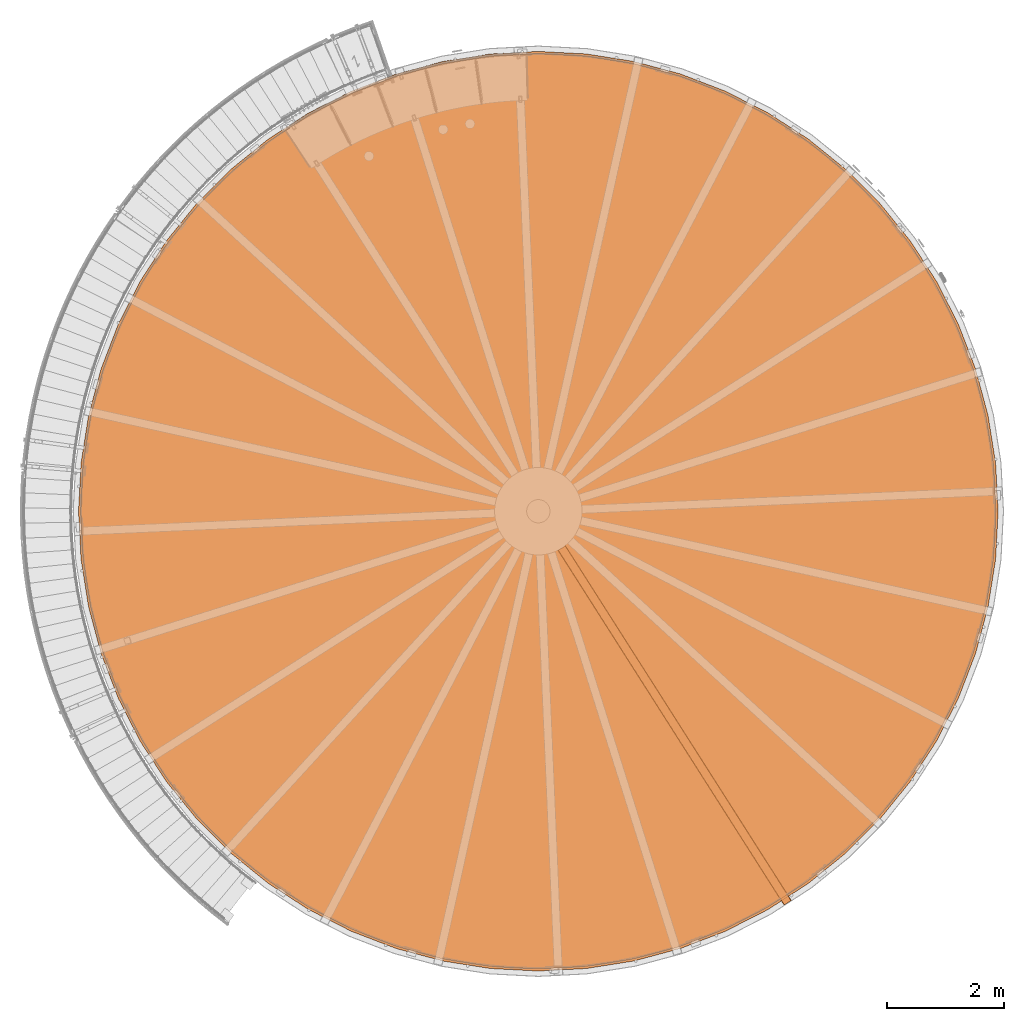
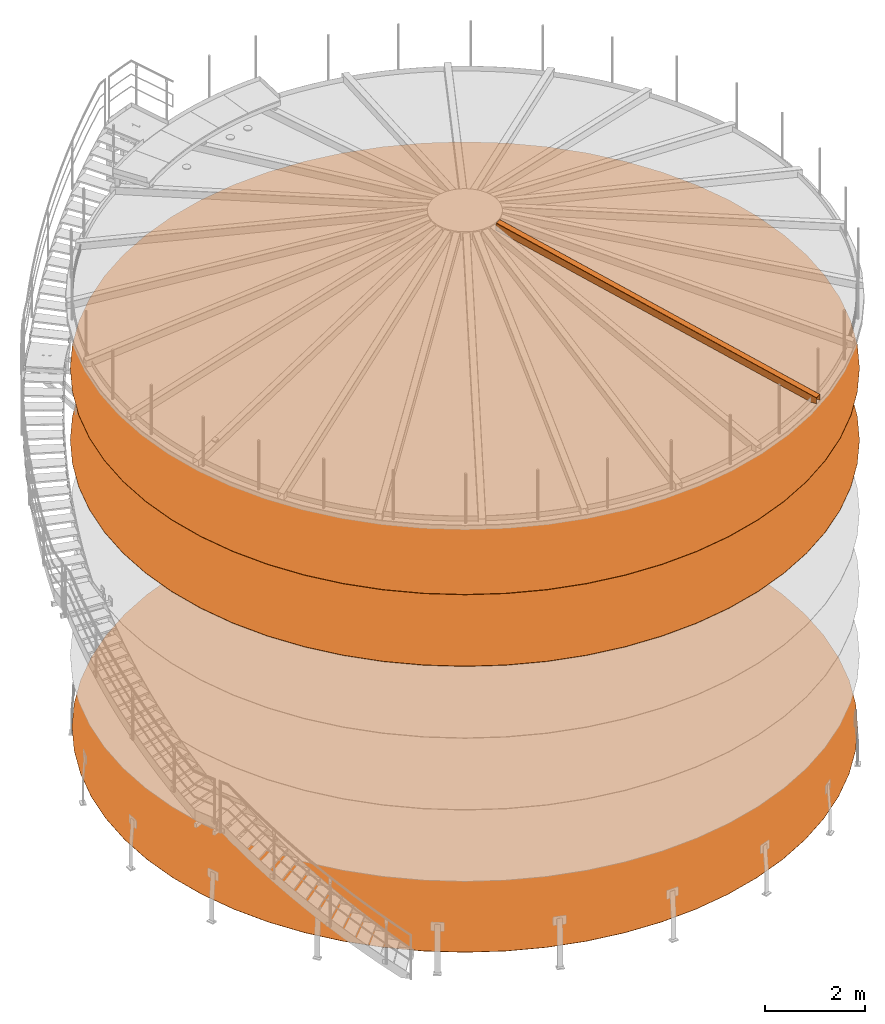
# One storey, part 19 of 126: 4 proxies.
"""IFC2X3 building model written with IfcOpenShell, lengths in millimetres."""

import ifcopenshell
import ifcopenshell.guid

model = None  # the IFC model being written
_history = None  # IfcOwnerHistory: only IFC2X3 demands one
_inside = {}  # id of a spatial element -> (the spatial element, [elements in it])
_under = {}  # id of a project, library or spatial element -> (it, [spatial elements below it])
_declared = {}  # id of a project -> (the project, [libraries it declares])
_typed = {}  # id of a type object -> (the type object, [elements of that type])
_made_of = {}  # id of a material, layer set ... -> (it, [elements and type objects made of it])


def new_model(schema):
    """Start an empty IFC model of exactly this schema.

    Asked for "IFC4X3", IfcOpenShell would pick the latest addendum, in which some entities
    have other attributes; the version numbers below select the first issue.
    IFC2X3 requires an IfcOwnerHistory on every rooted entity: one is made here for all.
    """
    global model, _history
    if schema == "IFC4X3":
        model = ifcopenshell.file(schema_version=(4, 3, 0, 0))
    else:
        model = ifcopenshell.file(schema=schema)
    _inside.clear()
    _under.clear()
    _declared.clear()
    _typed.clear()
    _made_of.clear()
    _history = None
    if model.schema == "IFC2X3":
        org = make("IfcOrganization", Name="unknown")
        user = make(
            "IfcPersonAndOrganization",
            ThePerson=make("IfcPerson", FamilyName="unknown"),
            TheOrganization=org,
        )
        app = make(
            "IfcApplication",
            ApplicationDeveloper=org,
            Version="unknown",
            ApplicationFullName="unknown",
            ApplicationIdentifier="unknown",
        )
        _history = make(
            "IfcOwnerHistory",
            OwningUser=user,
            OwningApplication=app,
            ChangeAction="ADDED",
            CreationDate=0,
        )
    return model


def make(cls, **values):
    """One entity of the class cls with the attributes given. An attribute that is None is left unset."""
    return model.create_entity(
        cls, **{name: value for name, value in values.items() if value is not None}
    )


def rooted(cls, **values):
    """An entity with a GlobalId (a new one), such as an element, a storey or a relation."""
    return make(cls, GlobalId=ifcopenshell.guid.new(), OwnerHistory=_history, **values)


def si_unit(unit_type, name, prefix=None):
    """IfcSIUnit, for example si_unit("LENGTHUNIT", "METRE", prefix="MILLI")."""
    return make("IfcSIUnit", UnitType=unit_type, Prefix=prefix, Name=name)


def assignment(units):
    """IfcUnitAssignment: the units of a project."""
    return None if units is None else make("IfcUnitAssignment", Units=units)


def point(xyz):
    """IfcCartesianPoint."""
    return None if xyz is None else make("IfcCartesianPoint", Coordinates=xyz)


def direction(xyz):
    """IfcDirection."""
    return None if xyz is None else make("IfcDirection", DirectionRatios=xyz)


def frame(location, z_axis=None, x_axis=None):
    """IfcAxis2Placement3D, a coordinate frame: its origin and axes. An axis left out is left unset."""
    return make(
        "IfcAxis2Placement3D",
        Location=point(location),
        Axis=direction(z_axis),
        RefDirection=direction(x_axis),
    )


def origin():
    """The frame at (0, 0, 0) with its axes left unset."""
    return frame((0.0, 0.0, 0.0))


def origin_with_axes():
    """The frame at (0, 0, 0) with the z axis (0, 0, 1) and the x axis (1, 0, 0) written out."""
    return frame((0.0, 0.0, 0.0), z_axis=(0.0, 0.0, 1.0), x_axis=(1.0, 0.0, 0.0))


def place(relative_to, where):
    """IfcLocalPlacement: puts the frame where relative to a parent placement (None: the world)."""
    return make(
        "IfcLocalPlacement", PlacementRelTo=relative_to, RelativePlacement=where
    )


def context(
    kind, dimensions, precision=None, world=None, true_north=None, identifier=None
):
    """IfcGeometricRepresentationContext, for example the 3D "Model" context."""
    return make(
        "IfcGeometricRepresentationContext",
        ContextIdentifier=identifier,
        ContextType=kind,
        CoordinateSpaceDimension=dimensions,
        Precision=precision,
        WorldCoordinateSystem=world,
        TrueNorth=true_north,
    )


def project(units=None, contexts=None):
    """IfcProject with its units and contexts."""
    return rooted(
        "IfcProject",
        Name="project",
        RepresentationContexts=contexts,
        UnitsInContext=assignment(units),
    )


def spatial(cls, under=None, at=None, **own):
    """A site, building, storey or space (cls), placed at a placement, below another one or the project."""
    s = rooted(cls, ObjectPlacement=at, **own)
    if under is not None:
        _under.setdefault(under.id(), (under, []))[1].append(s)
    return s


def faces_of(points, faces, orient=None, outer=None):
    """IfcFace entities. A face is a list of loops; a loop is a list of indices into points, from 0.

    orient and outer hold one flag for each loop. By default every Orientation is true, the
    first loop of a face is its IfcFaceOuterBound and the others are IfcFaceBound.
    """
    made = []
    for i, loops in enumerate(faces):
        bounds = []
        for j, loop in enumerate(loops):
            is_outer = j == 0 if outer is None else outer[i][j]
            bounds.append(
                make(
                    "IfcFaceOuterBound" if is_outer else "IfcFaceBound",
                    Bound=make("IfcPolyLoop", Polygon=[points[k] for k in loop]),
                    Orientation=True if orient is None else orient[i][j],
                )
            )
        made.append(make("IfcFace", Bounds=bounds))
    return made


def faceted_brep(points, faces, orient=None, outer=None, voids=None):
    """IfcFacetedBrep: a solid bounded by flat faces; with voids (closed shells), ...WithVoids."""
    shared = [point(p) for p in points]
    hull = make("IfcClosedShell", CfsFaces=faces_of(shared, faces, orient, outer))
    if voids is None:
        return make("IfcFacetedBrep", Outer=hull)
    return make(
        "IfcFacetedBrepWithVoids",
        Outer=hull,
        Voids=[
            make(cls, CfsFaces=faces_of(shared, fs, o, b)) for cls, fs, o, b in voids
        ],
    )


def shape(context_of_items, identifier, shape_type, items):
    """IfcShapeRepresentation: the items that make up one representation, for example the "Body"."""
    return make(
        "IfcShapeRepresentation",
        ContextOfItems=context_of_items,
        RepresentationIdentifier=identifier,
        RepresentationType=shape_type,
        Items=items,
    )


def material(Name=None, Category=None):
    """IfcMaterial."""
    return make("IfcMaterial", Name=Name, Category=Category)


def made_of(thing, what):
    """Note that an element or type object is made of a material, layer set ...; save() writes the relation."""
    if what is not None:
        _made_of.setdefault(what.id(), (what, []))[1].append(thing)
    return thing


def element(
    cls,
    number,
    at=None,
    inside=None,
    cuts=None,
    type_object=None,
    material=None,
    context=None,
    identifier="Body",
    shape_type=None,
    held_by="IfcProductDefinitionShape",
    body=None,
    shapes=None,
    **own,
):
    """One element of the class cls, such as IfcWall. Its Tag is "e" and its number.

    at: its placement. inside: the storey or other place that contains it. cuts: it is an
    opening in that element (IfcRelVoidsElement). A single representation is given by context,
    identifier, shape_type and body (its items); several are given by shapes. held_by: the class
    of the entity that holds the representations. save() writes the other relations.
    """
    e = rooted(cls, Tag="e%d" % number, ObjectPlacement=at, **own)
    if body is not None:
        shapes = [shape(context, identifier, shape_type, body)]
    if shapes is not None:
        e.Representation = make(held_by, Representations=shapes)
    if inside is not None:
        _inside.setdefault(inside.id(), (inside, []))[1].append(e)
    if cuts is not None:
        rooted(
            "IfcRelVoidsElement", RelatingBuildingElement=cuts, RelatedOpeningElement=e
        )
    if type_object is not None:
        _typed.setdefault(type_object.id(), (type_object, []))[1].append(e)
    return made_of(e, material)


def aggregate(whole, parts):
    """IfcRelAggregates: a whole, such as a stair, and the parts it consists of."""
    return rooted("IfcRelAggregates", RelatingObject=whole, RelatedObjects=parts)


def save(model, path):
    """Write the relations noted so far, then the file.

    IfcRelAggregates (storeys below a building ...), IfcRelContainedInSpatialStructure (elements
    in a storey), IfcRelDefinesByType, IfcRelAssociatesMaterial and IfcRelDeclares: one each for
    every whole, place, type object, material and project.
    """
    for whole, parts in _under.values():
        aggregate(whole, parts)
    for where, things in _inside.values():
        rooted(
            "IfcRelContainedInSpatialStructure",
            RelatedElements=things,
            RelatingStructure=where,
        )
    for kind, things in _typed.values():
        rooted("IfcRelDefinesByType", RelatedObjects=things, RelatingType=kind)
    for what, things in _made_of.values():
        rooted("IfcRelAssociatesMaterial", RelatedObjects=things, RelatingMaterial=what)
    for by, libraries in _declared.values():
        rooted("IfcRelDeclares", RelatingContext=by, RelatedDefinitions=libraries)
    model.write(path)


model = new_model("IFC2X3")

# Units and contexts
context_of_model_1 = context(None, 3, precision=0.1, world=origin())
context_of_model_2 = context(None, 3, precision=0.1, world=origin())
ifc_project = project(units=[si_unit("LENGTHUNIT", "METRE", prefix="MILLI"), si_unit("AREAUNIT", "SQUARE_METRE", prefix="CENTI"), si_unit("VOLUMEUNIT", "CUBIC_METRE", prefix="CENTI"), si_unit("MASSUNIT", "GRAM", prefix="KILO")], contexts=[context_of_model_1, context_of_model_2])

# Site, building, storey
site_placement = place(None, origin_with_axes())
site = spatial("IfcSite", under=ifc_project, at=site_placement, CompositionType="ELEMENT")
building_placement = place(site_placement, origin_with_axes())
building = spatial("IfcBuilding", under=site, at=building_placement, CompositionType="ELEMENT")
storey_placement = place(building_placement, origin_with_axes())
storey = spatial("IfcBuildingStorey", under=building, at=storey_placement, CompositionType="ELEMENT")

# Proxies
ifc_material = material(Name="STAHL")
proxy_1_placement = place(storey_placement, origin_with_axes())
element("IfcBuildingElementProxy", 1, at=proxy_1_placement, inside=storey, material=ifc_material, Name="profile", context=context_of_model_2, shape_type="Brep", body=[
    faceted_brep([(4812.1, 833.7, 0.0), (5579.2, 539.2, 0.0), (5579.2, 539.2, 6.0), (4812.1, 833.7, 6.0), (4080.0, 1206.7, 0.0), (4080.0, 1206.7, 6.0), (3390.9, 1654.2, 0.0), (3390.9, 1654.2, 6.0), (15812.0, 7184.5, 0.0), (15855.0, 8005.0, 0.0), (15855.0, 8005.0, 6.0), (15812.0, 7184.5, 6.0), (2752.3, 2171.3, 0.0), (2752.3, 2171.3, 6.0), (15683.5, 6372.9, 0.0), (15683.5, 6372.9, 6.0), (2171.3, 2752.3, 0.0), (2171.3, 2752.3, 6.0), (15470.8, 5579.2, 0.0), (15470.8, 5579.2, 6.0), (1654.2, 3390.9, 0.0), (1654.2, 3390.9, 6.0), (15176.3, 4812.1, 0.0), (15176.3, 4812.1, 6.0), (1206.7, 4080.0, 0.0), (1206.7, 4080.0, 6.0), (14803.3, 4080.0, 0.0), (14803.3, 4080.0, 6.0), (833.7, 4812.1, 0.0), (833.7, 4812.1, 6.0), (14355.8, 3390.9, 0.0), (14355.8, 3390.9, 6.0), (539.2, 5579.2, 0.0), (539.2, 5579.2, 6.0), (13838.7, 2752.3, 0.0), (13838.7, 2752.3, 6.0), (326.5, 6372.9, 0.0), (326.5, 6372.9, 6.0), (13257.7, 2171.3, 0.0), (13257.7, 2171.3, 6.0), (198.0, 7184.5, 0.0), (198.0, 7184.5, 6.0), (12619.1, 1654.2, 0.0), (12619.1, 1654.2, 6.0), (155.0, 8005.0, 0.0), (155.0, 8005.0, 6.0), (11930.0, 1206.7, 0.0), (11930.0, 1206.7, 6.0), (11197.9, 833.7, 0.0), (11197.9, 833.7, 6.0), (10430.8, 539.2, 0.0), (10430.8, 539.2, 6.0), (9637.1, 326.5, 0.0), (9637.1, 326.5, 6.0), (8825.5, 198.0, 0.0), (8825.5, 198.0, 6.0), (8005.0, 155.0, 0.0), (8005.0, 155.0, 6.0), (7184.5, 198.0, 0.0), (7184.5, 198.0, 6.0), (6372.9, 326.5, 0.0), (6372.9, 326.5, 6.0), (11197.9, 15176.3, 0.0), (10430.8, 15470.8, 0.0), (10430.8, 15470.8, 6.0), (11197.9, 15176.3, 6.0), (11930.0, 14803.3, 0.0), (11930.0, 14803.3, 6.0), (12619.1, 14355.8, 0.0), (12619.1, 14355.8, 6.0), (198.0, 8825.5, 0.0), (198.0, 8825.5, 6.0), (13257.7, 13838.7, 0.0), (13257.7, 13838.7, 6.0), (326.5, 9637.1, 0.0), (326.5, 9637.1, 6.0), (13838.7, 13257.7, 0.0), (13838.7, 13257.7, 6.0), (539.2, 10430.8, 0.0), (539.2, 10430.8, 6.0), (14355.8, 12619.1, 0.0), (14355.8, 12619.1, 6.0), (833.7, 11197.9, 0.0), (833.7, 11197.9, 6.0), (14803.3, 11930.0, 0.0), (14803.3, 11930.0, 6.0), (1206.7, 11930.0, 0.0), (1206.7, 11930.0, 6.0), (15176.3, 11197.9, 0.0), (15176.3, 11197.9, 6.0), (1654.2, 12619.1, 0.0), (1654.2, 12619.1, 6.0), (15470.8, 10430.8, 0.0), (15470.8, 10430.8, 6.0), (2171.3, 13257.7, 0.0), (2171.3, 13257.7, 6.0), (15683.5, 9637.1, 0.0), (15683.5, 9637.1, 6.0), (2752.3, 13838.7, 0.0), (2752.3, 13838.7, 6.0), (15812.0, 8825.5, 0.0), (15812.0, 8825.5, 6.0), (3390.9, 14355.8, 0.0), (3390.9, 14355.8, 6.0), (4080.0, 14803.3, 0.0), (4080.0, 14803.3, 6.0), (4812.1, 15176.3, 0.0), (4812.1, 15176.3, 6.0), (5579.2, 15470.8, 0.0), (5579.2, 15470.8, 6.0), (6372.9, 15683.5, 0.0), (6372.9, 15683.5, 6.0), (7184.5, 15812.0, 0.0), (7184.5, 15812.0, 6.0), (8005.0, 15855.0, 0.0), (8005.0, 15855.0, 6.0), (8825.5, 15812.0, 0.0), (8825.5, 15812.0, 6.0), (9637.1, 15683.5, 0.0), (9637.1, 15683.5, 6.0)], [[[0, 1, 2, 3]], [[4, 0, 3, 5]], [[6, 4, 5, 7]], [[8, 9, 10, 11]], [[12, 6, 7, 13]], [[14, 8, 11, 15]], [[16, 12, 13, 17]], [[18, 14, 15, 19]], [[20, 16, 17, 21]], [[22, 18, 19, 23]], [[24, 20, 21, 25]], [[26, 22, 23, 27]], [[28, 24, 25, 29]], [[30, 26, 27, 31]], [[32, 28, 29, 33]], [[34, 30, 31, 35]], [[36, 32, 33, 37]], [[38, 34, 35, 39]], [[40, 36, 37, 41]], [[42, 38, 39, 43]], [[44, 40, 41, 45]], [[46, 42, 43, 47]], [[48, 46, 47, 49]], [[50, 48, 49, 51]], [[52, 50, 51, 53]], [[54, 52, 53, 55]], [[56, 54, 55, 57]], [[58, 56, 57, 59]], [[60, 58, 59, 61]], [[1, 60, 61, 2]], [[62, 63, 64, 65]], [[66, 62, 65, 67]], [[68, 66, 67, 69]], [[70, 44, 45, 71]], [[72, 68, 69, 73]], [[74, 70, 71, 75]], [[76, 72, 73, 77]], [[78, 74, 75, 79]], [[80, 76, 77, 81]], [[82, 78, 79, 83]], [[84, 80, 81, 85]], [[86, 82, 83, 87]], [[88, 84, 85, 89]], [[90, 86, 87, 91]], [[92, 88, 89, 93]], [[94, 90, 91, 95]], [[96, 92, 93, 97]], [[98, 94, 95, 99]], [[100, 96, 97, 101]], [[102, 98, 99, 103]], [[9, 100, 101, 10]], [[104, 102, 103, 105]], [[106, 104, 105, 107]], [[108, 106, 107, 109]], [[110, 108, 109, 111]], [[112, 110, 111, 113]], [[114, 112, 113, 115]], [[116, 114, 115, 117]], [[118, 116, 117, 119]], [[63, 118, 119, 64]], [[56, 58, 60, 1, 0, 4, 6, 12, 16, 20, 24, 28, 32, 36, 40, 44, 70, 74, 78, 82, 86, 90, 94, 98, 102, 104, 106, 108, 110, 112, 114, 116, 118, 63, 62, 66, 68, 72, 76, 80, 84, 88, 92, 96, 100, 9, 8, 14, 18, 22, 26, 30, 34, 38, 42, 46, 48, 50, 52, 54]], [[57, 55, 53, 51, 49, 47, 43, 39, 35, 31, 27, 23, 19, 15, 11, 10, 101, 97, 93, 89, 85, 81, 77, 73, 69, 67, 65, 64, 119, 117, 115, 113, 111, 109, 107, 105, 103, 99, 95, 91, 87, 83, 79, 75, 71, 45, 41, 37, 33, 29, 25, 21, 17, 13, 7, 5, 3, 2, 61, 59]]]),
])
proxy_2_placement = place(storey_placement, origin_with_axes())
element("IfcBuildingElementProxy", 2, at=proxy_2_placement, inside=storey, material=ifc_material, Name="profile", context=context_of_model_2, shape_type="Brep", body=[
    faceted_brep([(4062.5, 14833.6, 8756.0), (4797.9, 15208.3, 8756.0), (4797.9, 15208.3, 8748.0), (4062.5, 14833.6, 8748.0), (15890.0, 8005.0, 8756.0), (15890.0, 8005.0, 8748.0), (15846.8, 8829.2, 8748.0), (15846.8, 8829.2, 8756.0), (3370.3, 14384.1, 8756.0), (3370.3, 14384.1, 8748.0), (15717.7, 9644.4, 8748.0), (15717.7, 9644.4, 8756.0), (2728.9, 13864.7, 8756.0), (2728.9, 13864.7, 8748.0), (2145.3, 13281.1, 8756.0), (2145.3, 13281.1, 8748.0), (15504.1, 10441.6, 8756.0), (15504.1, 10441.6, 8748.0), (1625.9, 12639.7, 8756.0), (1625.9, 12639.7, 8748.0), (15208.3, 11212.1, 8756.0), (15208.3, 11212.1, 8748.0), (1176.4, 11947.5, 8756.0), (1176.4, 11947.5, 8748.0), (14833.6, 11947.5, 8756.0), (14833.6, 11947.5, 8748.0), (801.7, 11212.1, 8756.0), (801.7, 11212.1, 8748.0), (14384.1, 12639.7, 8756.0), (14384.1, 12639.7, 8748.0), (505.9, 10441.6, 8756.0), (505.9, 10441.6, 8748.0), (13864.7, 13281.1, 8756.0), (13864.7, 13281.1, 8748.0), (292.3, 9644.4, 8756.0), (292.3, 9644.4, 8748.0), (13281.1, 13864.7, 8756.0), (13281.1, 13864.7, 8748.0), (163.2, 8829.2, 8756.0), (163.2, 8829.2, 8748.0), (12639.7, 14384.1, 8756.0), (12639.7, 14384.1, 8748.0), (120.0, 8005.0, 8756.0), (120.0, 8005.0, 8748.0), (11947.5, 14833.6, 8756.0), (11947.5, 14833.6, 8748.0), (11212.1, 15208.3, 8756.0), (11212.1, 15208.3, 8748.0), (10441.6, 15504.1, 8756.0), (10441.6, 15504.1, 8748.0), (9644.4, 15717.7, 8756.0), (9644.4, 15717.7, 8748.0), (8829.2, 15846.8, 8756.0), (8829.2, 15846.8, 8748.0), (8005.0, 15890.0, 8756.0), (8005.0, 15890.0, 8748.0), (7180.8, 15846.8, 8756.0), (7180.8, 15846.8, 8748.0), (6365.6, 15717.7, 8756.0), (6365.6, 15717.7, 8748.0), (5568.4, 15504.1, 8756.0), (5568.4, 15504.1, 8748.0), (11179.6, 874.8, 8756.0), (11179.6, 874.8, 8748.0), (10416.9, 582.0, 8748.0), (10416.9, 582.0, 8756.0), (11907.5, 1245.7, 8756.0), (11907.5, 1245.7, 8748.0), (200.0, 8005.0, 8756.0), (242.8, 7189.2, 8756.0), (242.8, 7189.2, 8748.0), (200.0, 8005.0, 8748.0), (12592.7, 1690.6, 8756.0), (12592.7, 1690.6, 8748.0), (13227.6, 2204.8, 8756.0), (13227.6, 2204.8, 8748.0), (370.6, 6382.2, 8756.0), (370.6, 6382.2, 8748.0), (13805.2, 2782.4, 8756.0), (13805.2, 2782.4, 8748.0), (582.0, 5593.1, 8756.0), (582.0, 5593.1, 8748.0), (14319.4, 3417.3, 8756.0), (14319.4, 3417.3, 8748.0), (874.8, 4830.4, 8756.0), (874.8, 4830.4, 8748.0), (14764.3, 4102.5, 8756.0), (14764.3, 4102.5, 8748.0), (1245.7, 4102.5, 8756.0), (1245.7, 4102.5, 8748.0), (15135.2, 4830.4, 8756.0), (15135.2, 4830.4, 8748.0), (1690.6, 3417.3, 8756.0), (1690.6, 3417.3, 8748.0), (15428.0, 5593.1, 8756.0), (15428.0, 5593.1, 8748.0), (2204.8, 2782.4, 8756.0), (2204.8, 2782.4, 8748.0), (15639.4, 6382.2, 8756.0), (15639.4, 6382.2, 8748.0), (2782.4, 2204.8, 8756.0), (2782.4, 2204.8, 8748.0), (15767.2, 7189.2, 8756.0), (15767.2, 7189.2, 8748.0), (3417.3, 1690.6, 8756.0), (3417.3, 1690.6, 8748.0), (15810.0, 8005.0, 8756.0), (15810.0, 8005.0, 8748.0), (4102.5, 1245.7, 8756.0), (4102.5, 1245.7, 8748.0), (4830.4, 874.8, 8756.0), (4830.4, 874.8, 8748.0), (5593.1, 582.0, 8756.0), (5593.1, 582.0, 8748.0), (6382.2, 370.6, 8756.0), (6382.2, 370.6, 8748.0), (7189.2, 242.8, 8756.0), (7189.2, 242.8, 8748.0), (8005.0, 200.0, 8756.0), (8005.0, 200.0, 8748.0), (8820.8, 242.8, 8756.0), (8820.8, 242.8, 8748.0), (9627.8, 370.6, 8756.0), (9627.8, 370.6, 8748.0), (8005.0, 120.0, 8756.0), (8829.2, 163.2, 8756.0), (9644.4, 292.3, 8756.0), (10441.6, 505.9, 8756.0), (11212.1, 801.7, 8756.0), (11947.5, 1176.4, 8756.0), (12639.7, 1625.9, 8756.0), (13281.1, 2145.3, 8756.0), (13864.7, 2728.9, 8756.0), (14384.1, 3370.3, 8756.0), (14833.6, 4062.5, 8756.0), (15208.3, 4797.9, 8756.0), (15504.1, 5568.4, 8756.0), (15717.7, 6365.6, 8756.0), (15846.8, 7180.8, 8756.0), (163.2, 7180.8, 8756.0), (292.3, 6365.6, 8756.0), (505.9, 5568.4, 8756.0), (801.7, 4797.9, 8756.0), (1176.4, 4062.5, 8756.0), (1625.9, 3370.3, 8756.0), (2145.3, 2728.9, 8756.0), (2728.9, 2145.3, 8756.0), (242.8, 8820.8, 8756.0), (370.6, 9627.8, 8756.0), (582.0, 10416.9, 8756.0), (874.8, 11179.6, 8756.0), (1245.7, 11907.5, 8756.0), (1690.6, 12592.7, 8756.0), (2204.8, 13227.6, 8756.0), (2782.4, 13805.2, 8756.0), (3417.3, 14319.4, 8756.0), (4102.5, 14764.3, 8756.0), (4830.4, 15135.2, 8756.0), (5593.1, 15428.0, 8756.0), (6382.2, 15639.4, 8756.0), (7189.2, 15767.2, 8756.0), (8005.0, 15810.0, 8756.0), (8820.8, 15767.2, 8756.0), (9627.8, 15639.4, 8756.0), (10416.9, 15428.0, 8756.0), (11179.6, 15135.2, 8756.0), (11907.5, 14764.3, 8756.0), (12592.7, 14319.4, 8756.0), (13227.6, 13805.2, 8756.0), (13805.2, 13227.6, 8756.0), (14319.4, 12592.7, 8756.0), (14764.3, 11907.5, 8756.0), (15135.2, 11179.6, 8756.0), (15428.0, 10416.9, 8756.0), (15639.4, 9627.8, 8756.0), (15767.2, 8820.8, 8756.0), (3370.3, 1625.9, 8756.0), (4062.5, 1176.4, 8756.0), (4797.9, 801.7, 8756.0), (5568.4, 505.9, 8756.0), (6365.6, 292.3, 8756.0), (7180.8, 163.2, 8756.0), (4830.4, 15135.2, 8748.0), (5593.1, 15428.0, 8748.0), (4102.5, 14764.3, 8748.0), (3417.3, 14319.4, 8748.0), (15767.2, 8820.8, 8748.0), (2782.4, 13805.2, 8748.0), (15639.4, 9627.8, 8748.0), (2204.8, 13227.6, 8748.0), (15428.0, 10416.9, 8748.0), (1690.6, 12592.7, 8748.0), (15135.2, 11179.6, 8748.0), (1245.7, 11907.5, 8748.0), (14764.3, 11907.5, 8748.0), (874.8, 11179.6, 8748.0), (14319.4, 12592.7, 8748.0), (582.0, 10416.9, 8748.0), (13805.2, 13227.6, 8748.0), (370.6, 9627.8, 8748.0), (13227.6, 13805.2, 8748.0), (242.8, 8820.8, 8748.0), (12592.7, 14319.4, 8748.0), (11907.5, 14764.3, 8748.0), (11179.6, 15135.2, 8748.0), (10416.9, 15428.0, 8748.0), (9627.8, 15639.4, 8748.0), (8820.8, 15767.2, 8748.0), (8005.0, 15810.0, 8748.0), (7189.2, 15767.2, 8748.0), (6382.2, 15639.4, 8748.0), (8005.0, 120.0, 8748.0), (7180.8, 163.2, 8748.0), (6365.6, 292.3, 8748.0), (5568.4, 505.9, 8748.0), (4797.9, 801.7, 8748.0), (4062.5, 1176.4, 8748.0), (3370.3, 1625.9, 8748.0), (2728.9, 2145.3, 8748.0), (2145.3, 2728.9, 8748.0), (1625.9, 3370.3, 8748.0), (1176.4, 4062.5, 8748.0), (801.7, 4797.9, 8748.0), (505.9, 5568.4, 8748.0), (292.3, 6365.6, 8748.0), (163.2, 7180.8, 8748.0), (15846.8, 7180.8, 8748.0), (15717.7, 6365.6, 8748.0), (15504.1, 5568.4, 8748.0), (15208.3, 4797.9, 8748.0), (14833.6, 4062.5, 8748.0), (14384.1, 3370.3, 8748.0), (13864.7, 2728.9, 8748.0), (13281.1, 2145.3, 8748.0), (12639.7, 1625.9, 8748.0), (11947.5, 1176.4, 8748.0), (11212.1, 801.7, 8748.0), (10441.6, 505.9, 8748.0), (9644.4, 292.3, 8748.0), (8829.2, 163.2, 8748.0)], [[[0, 1, 2, 3]], [[4, 5, 6, 7]], [[8, 0, 3, 9]], [[7, 6, 10, 11]], [[12, 8, 9, 13]], [[14, 12, 13, 15]], [[16, 11, 10, 17]], [[18, 14, 15, 19]], [[20, 16, 17, 21]], [[22, 18, 19, 23]], [[24, 20, 21, 25]], [[26, 22, 23, 27]], [[28, 24, 25, 29]], [[30, 26, 27, 31]], [[32, 28, 29, 33]], [[34, 30, 31, 35]], [[36, 32, 33, 37]], [[38, 34, 35, 39]], [[40, 36, 37, 41]], [[42, 38, 39, 43]], [[44, 40, 41, 45]], [[46, 44, 45, 47]], [[48, 46, 47, 49]], [[50, 48, 49, 51]], [[52, 50, 51, 53]], [[54, 52, 53, 55]], [[56, 54, 55, 57]], [[58, 56, 57, 59]], [[60, 58, 59, 61]], [[1, 60, 61, 2]], [[62, 63, 64, 65]], [[66, 67, 63, 62]], [[68, 69, 70, 71]], [[72, 73, 67, 66]], [[74, 75, 73, 72]], [[76, 77, 70, 69]], [[78, 79, 75, 74]], [[80, 81, 77, 76]], [[82, 83, 79, 78]], [[84, 85, 81, 80]], [[86, 87, 83, 82]], [[88, 89, 85, 84]], [[90, 91, 87, 86]], [[92, 93, 89, 88]], [[94, 95, 91, 90]], [[96, 97, 93, 92]], [[98, 99, 95, 94]], [[100, 101, 97, 96]], [[102, 103, 99, 98]], [[104, 105, 101, 100]], [[106, 107, 103, 102]], [[108, 109, 105, 104]], [[110, 111, 109, 108]], [[112, 113, 111, 110]], [[114, 115, 113, 112]], [[116, 117, 115, 114]], [[118, 119, 117, 116]], [[120, 121, 119, 118]], [[122, 123, 121, 120]], [[65, 64, 123, 122]], [[124, 125, 126, 127, 128, 129, 130, 131, 132, 133, 134, 135, 136, 137, 138, 4, 7, 11, 16, 20, 24, 28, 32, 36, 40, 44, 46, 48, 50, 52, 54, 56, 58, 60, 1, 0, 8, 12, 14, 18, 22, 26, 30, 34, 38, 42, 139, 140, 141, 142, 143, 144, 145, 146, 96, 92, 88, 84, 80, 76, 69, 68, 147, 148, 149, 150, 151, 152, 153, 154, 155, 156, 157, 158, 159, 160, 161, 162, 163, 164, 165, 166, 167, 168, 169, 170, 171, 172, 173, 174, 175, 106, 102, 98, 94, 90, 86, 82, 78, 74, 72, 66, 62, 65, 122, 120, 118, 116, 114, 112, 110, 108, 104, 100, 96, 146, 176, 177, 178, 179, 180, 181]], [[157, 182, 183, 158]], [[156, 184, 182, 157]], [[155, 185, 184, 156]], [[175, 186, 107, 106]], [[154, 187, 185, 155]], [[174, 188, 186, 175]], [[153, 189, 187, 154]], [[173, 190, 188, 174]], [[152, 191, 189, 153]], [[172, 192, 190, 173]], [[151, 193, 191, 152]], [[171, 194, 192, 172]], [[150, 195, 193, 151]], [[170, 196, 194, 171]], [[149, 197, 195, 150]], [[169, 198, 196, 170]], [[148, 199, 197, 149]], [[168, 200, 198, 169]], [[147, 201, 199, 148]], [[167, 202, 200, 168]], [[68, 71, 201, 147]], [[166, 203, 202, 167]], [[165, 204, 203, 166]], [[164, 205, 204, 165]], [[163, 206, 205, 164]], [[162, 207, 206, 163]], [[161, 208, 207, 162]], [[160, 209, 208, 161]], [[159, 210, 209, 160]], [[158, 183, 210, 159]], [[211, 212, 213, 214, 215, 216, 217, 218, 219, 220, 221, 222, 223, 224, 225, 43, 39, 35, 31, 27, 23, 19, 15, 13, 9, 3, 2, 61, 59, 57, 55, 53, 51, 49, 47, 45, 41, 37, 33, 29, 25, 21, 17, 10, 6, 5, 226, 227, 228, 229, 230, 231, 232, 75, 79, 83, 87, 91, 95, 99, 103, 107, 186, 188, 190, 192, 194, 196, 198, 200, 202, 203, 204, 205, 206, 207, 208, 209, 210, 183, 182, 184, 185, 187, 189, 191, 193, 195, 197, 199, 201, 71, 70, 77, 81, 85, 89, 93, 97, 101, 105, 109, 111, 113, 115, 117, 119, 121, 123, 64, 63, 67, 73, 75, 232, 233, 234, 235, 236, 237, 238, 239]], [[128, 127, 237, 236]], [[129, 128, 236, 235]], [[130, 129, 235, 234]], [[139, 42, 43, 225]], [[131, 130, 234, 233]], [[140, 139, 225, 224]], [[140, 224, 223, 141]], [[132, 131, 233, 232]], [[133, 132, 232, 231]], [[142, 141, 223, 222]], [[134, 133, 231, 230]], [[143, 142, 222, 221]], [[135, 134, 230, 229]], [[144, 143, 221, 220]], [[136, 135, 229, 228]], [[145, 144, 220, 219]], [[137, 136, 228, 227]], [[146, 145, 219, 218]], [[138, 137, 227, 226]], [[176, 146, 218, 217]], [[4, 138, 226, 5]], [[177, 176, 217, 216]], [[178, 177, 216, 215]], [[179, 178, 215, 214]], [[180, 179, 214, 213]], [[181, 180, 213, 212]], [[124, 181, 212, 211]], [[125, 124, 211, 239]], [[126, 125, 239, 238]], [[127, 126, 238, 237]]]),
])
proxy_3_placement = place(storey_placement, origin_with_axes())
element("IfcBuildingElementProxy", 3, at=proxy_3_placement, inside=storey, material=ifc_material, Name="profile", context=context_of_model_2, shape_type="Brep", body=[
    faceted_brep([(4062.5, 14833.6, 7006.0), (4797.9, 15208.3, 7006.0), (4797.9, 15208.3, 6998.0), (4062.5, 14833.6, 6998.0), (15890.0, 8005.0, 7006.0), (15890.0, 8005.0, 6998.0), (15846.8, 8829.2, 6998.0), (15846.8, 8829.2, 7006.0), (3370.3, 14384.1, 7006.0), (3370.3, 14384.1, 6998.0), (15717.7, 9644.4, 6998.0), (15717.7, 9644.4, 7006.0), (2728.9, 13864.7, 7006.0), (2728.9, 13864.7, 6998.0), (2145.3, 13281.1, 7006.0), (2145.3, 13281.1, 6998.0), (15504.1, 10441.6, 7006.0), (15504.1, 10441.6, 6998.0), (1625.9, 12639.7, 7006.0), (1625.9, 12639.7, 6998.0), (15208.3, 11212.1, 7006.0), (15208.3, 11212.1, 6998.0), (1176.4, 11947.5, 7006.0), (1176.4, 11947.5, 6998.0), (14833.6, 11947.5, 7006.0), (14833.6, 11947.5, 6998.0), (801.7, 11212.1, 7006.0), (801.7, 11212.1, 6998.0), (14384.1, 12639.7, 7006.0), (14384.1, 12639.7, 6998.0), (505.9, 10441.6, 7006.0), (505.9, 10441.6, 6998.0), (13864.7, 13281.1, 7006.0), (13864.7, 13281.1, 6998.0), (292.3, 9644.4, 7006.0), (292.3, 9644.4, 6998.0), (13281.1, 13864.7, 7006.0), (13281.1, 13864.7, 6998.0), (163.2, 8829.2, 7006.0), (163.2, 8829.2, 6998.0), (12639.7, 14384.1, 7006.0), (12639.7, 14384.1, 6998.0), (120.0, 8005.0, 7006.0), (120.0, 8005.0, 6998.0), (11947.5, 14833.6, 7006.0), (11947.5, 14833.6, 6998.0), (11212.1, 15208.3, 7006.0), (11212.1, 15208.3, 6998.0), (10441.6, 15504.1, 7006.0), (10441.6, 15504.1, 6998.0), (9644.4, 15717.7, 7006.0), (9644.4, 15717.7, 6998.0), (8829.2, 15846.8, 7006.0), (8829.2, 15846.8, 6998.0), (8005.0, 15890.0, 7006.0), (8005.0, 15890.0, 6998.0), (7180.8, 15846.8, 7006.0), (7180.8, 15846.8, 6998.0), (6365.6, 15717.7, 7006.0), (6365.6, 15717.7, 6998.0), (5568.4, 15504.1, 7006.0), (5568.4, 15504.1, 6998.0), (11179.6, 874.8, 7006.0), (11179.6, 874.8, 6998.0), (10416.9, 582.0, 6998.0), (10416.9, 582.0, 7006.0), (11907.5, 1245.7, 7006.0), (11907.5, 1245.7, 6998.0), (200.0, 8005.0, 7006.0), (242.8, 7189.2, 7006.0), (242.8, 7189.2, 6998.0), (200.0, 8005.0, 6998.0), (12592.7, 1690.6, 7006.0), (12592.7, 1690.6, 6998.0), (13227.6, 2204.8, 7006.0), (13227.6, 2204.8, 6998.0), (370.6, 6382.2, 7006.0), (370.6, 6382.2, 6998.0), (13805.2, 2782.4, 7006.0), (13805.2, 2782.4, 6998.0), (582.0, 5593.1, 7006.0), (582.0, 5593.1, 6998.0), (14319.4, 3417.3, 7006.0), (14319.4, 3417.3, 6998.0), (874.8, 4830.4, 7006.0), (874.8, 4830.4, 6998.0), (14764.3, 4102.5, 7006.0), (14764.3, 4102.5, 6998.0), (1245.7, 4102.5, 7006.0), (1245.7, 4102.5, 6998.0), (15135.2, 4830.4, 7006.0), (15135.2, 4830.4, 6998.0), (1690.6, 3417.3, 7006.0), (1690.6, 3417.3, 6998.0), (15428.0, 5593.1, 7006.0), (15428.0, 5593.1, 6998.0), (2204.8, 2782.4, 7006.0), (2204.8, 2782.4, 6998.0), (15639.4, 6382.2, 7006.0), (15639.4, 6382.2, 6998.0), (2782.4, 2204.8, 7006.0), (2782.4, 2204.8, 6998.0), (15767.2, 7189.2, 7006.0), (15767.2, 7189.2, 6998.0), (3417.3, 1690.6, 7006.0), (3417.3, 1690.6, 6998.0), (15810.0, 8005.0, 7006.0), (15810.0, 8005.0, 6998.0), (4102.5, 1245.7, 7006.0), (4102.5, 1245.7, 6998.0), (4830.4, 874.8, 7006.0), (4830.4, 874.8, 6998.0), (5593.1, 582.0, 7006.0), (5593.1, 582.0, 6998.0), (6382.2, 370.6, 7006.0), (6382.2, 370.6, 6998.0), (7189.2, 242.8, 7006.0), (7189.2, 242.8, 6998.0), (8005.0, 200.0, 7006.0), (8005.0, 200.0, 6998.0), (8820.8, 242.8, 7006.0), (8820.8, 242.8, 6998.0), (9627.8, 370.6, 7006.0), (9627.8, 370.6, 6998.0), (8005.0, 120.0, 7006.0), (8829.2, 163.2, 7006.0), (9644.4, 292.3, 7006.0), (10441.6, 505.9, 7006.0), (11212.1, 801.7, 7006.0), (11947.5, 1176.4, 7006.0), (12639.7, 1625.9, 7006.0), (13281.1, 2145.3, 7006.0), (13864.7, 2728.9, 7006.0), (14384.1, 3370.3, 7006.0), (14833.6, 4062.5, 7006.0), (15208.3, 4797.9, 7006.0), (15504.1, 5568.4, 7006.0), (15717.7, 6365.6, 7006.0), (15846.8, 7180.8, 7006.0), (163.2, 7180.8, 7006.0), (292.3, 6365.6, 7006.0), (505.9, 5568.4, 7006.0), (801.7, 4797.9, 7006.0), (1176.4, 4062.5, 7006.0), (1625.9, 3370.3, 7006.0), (2145.3, 2728.9, 7006.0), (2728.9, 2145.3, 7006.0), (242.8, 8820.8, 7006.0), (370.6, 9627.8, 7006.0), (582.0, 10416.9, 7006.0), (874.8, 11179.6, 7006.0), (1245.7, 11907.5, 7006.0), (1690.6, 12592.7, 7006.0), (2204.8, 13227.6, 7006.0), (2782.4, 13805.2, 7006.0), (3417.3, 14319.4, 7006.0), (4102.5, 14764.3, 7006.0), (4830.4, 15135.2, 7006.0), (5593.1, 15428.0, 7006.0), (6382.2, 15639.4, 7006.0), (7189.2, 15767.2, 7006.0), (8005.0, 15810.0, 7006.0), (8820.8, 15767.2, 7006.0), (9627.8, 15639.4, 7006.0), (10416.9, 15428.0, 7006.0), (11179.6, 15135.2, 7006.0), (11907.5, 14764.3, 7006.0), (12592.7, 14319.4, 7006.0), (13227.6, 13805.2, 7006.0), (13805.2, 13227.6, 7006.0), (14319.4, 12592.7, 7006.0), (14764.3, 11907.5, 7006.0), (15135.2, 11179.6, 7006.0), (15428.0, 10416.9, 7006.0), (15639.4, 9627.8, 7006.0), (15767.2, 8820.8, 7006.0), (3370.3, 1625.9, 7006.0), (4062.5, 1176.4, 7006.0), (4797.9, 801.7, 7006.0), (5568.4, 505.9, 7006.0), (6365.6, 292.3, 7006.0), (7180.8, 163.2, 7006.0), (4830.4, 15135.2, 6998.0), (5593.1, 15428.0, 6998.0), (4102.5, 14764.3, 6998.0), (3417.3, 14319.4, 6998.0), (15767.2, 8820.8, 6998.0), (2782.4, 13805.2, 6998.0), (15639.4, 9627.8, 6998.0), (2204.8, 13227.6, 6998.0), (15428.0, 10416.9, 6998.0), (1690.6, 12592.7, 6998.0), (15135.2, 11179.6, 6998.0), (1245.7, 11907.5, 6998.0), (14764.3, 11907.5, 6998.0), (874.8, 11179.6, 6998.0), (14319.4, 12592.7, 6998.0), (582.0, 10416.9, 6998.0), (13805.2, 13227.6, 6998.0), (370.6, 9627.8, 6998.0), (13227.6, 13805.2, 6998.0), (242.8, 8820.8, 6998.0), (12592.7, 14319.4, 6998.0), (11907.5, 14764.3, 6998.0), (11179.6, 15135.2, 6998.0), (10416.9, 15428.0, 6998.0), (9627.8, 15639.4, 6998.0), (8820.8, 15767.2, 6998.0), (8005.0, 15810.0, 6998.0), (7189.2, 15767.2, 6998.0), (6382.2, 15639.4, 6998.0), (8005.0, 120.0, 6998.0), (7180.8, 163.2, 6998.0), (6365.6, 292.3, 6998.0), (5568.4, 505.9, 6998.0), (4797.9, 801.7, 6998.0), (4062.5, 1176.4, 6998.0), (3370.3, 1625.9, 6998.0), (2728.9, 2145.3, 6998.0), (2145.3, 2728.9, 6998.0), (1625.9, 3370.3, 6998.0), (1176.4, 4062.5, 6998.0), (801.7, 4797.9, 6998.0), (505.9, 5568.4, 6998.0), (292.3, 6365.6, 6998.0), (163.2, 7180.8, 6998.0), (15846.8, 7180.8, 6998.0), (15717.7, 6365.6, 6998.0), (15504.1, 5568.4, 6998.0), (15208.3, 4797.9, 6998.0), (14833.6, 4062.5, 6998.0), (14384.1, 3370.3, 6998.0), (13864.7, 2728.9, 6998.0), (13281.1, 2145.3, 6998.0), (12639.7, 1625.9, 6998.0), (11947.5, 1176.4, 6998.0), (11212.1, 801.7, 6998.0), (10441.6, 505.9, 6998.0), (9644.4, 292.3, 6998.0), (8829.2, 163.2, 6998.0)], [[[0, 1, 2, 3]], [[4, 5, 6, 7]], [[8, 0, 3, 9]], [[7, 6, 10, 11]], [[12, 8, 9, 13]], [[14, 12, 13, 15]], [[16, 11, 10, 17]], [[18, 14, 15, 19]], [[20, 16, 17, 21]], [[22, 18, 19, 23]], [[24, 20, 21, 25]], [[26, 22, 23, 27]], [[28, 24, 25, 29]], [[30, 26, 27, 31]], [[32, 28, 29, 33]], [[34, 30, 31, 35]], [[36, 32, 33, 37]], [[38, 34, 35, 39]], [[40, 36, 37, 41]], [[42, 38, 39, 43]], [[44, 40, 41, 45]], [[46, 44, 45, 47]], [[48, 46, 47, 49]], [[50, 48, 49, 51]], [[52, 50, 51, 53]], [[54, 52, 53, 55]], [[56, 54, 55, 57]], [[58, 56, 57, 59]], [[60, 58, 59, 61]], [[1, 60, 61, 2]], [[62, 63, 64, 65]], [[66, 67, 63, 62]], [[68, 69, 70, 71]], [[72, 73, 67, 66]], [[74, 75, 73, 72]], [[76, 77, 70, 69]], [[78, 79, 75, 74]], [[80, 81, 77, 76]], [[82, 83, 79, 78]], [[84, 85, 81, 80]], [[86, 87, 83, 82]], [[88, 89, 85, 84]], [[90, 91, 87, 86]], [[92, 93, 89, 88]], [[94, 95, 91, 90]], [[96, 97, 93, 92]], [[98, 99, 95, 94]], [[100, 101, 97, 96]], [[102, 103, 99, 98]], [[104, 105, 101, 100]], [[106, 107, 103, 102]], [[108, 109, 105, 104]], [[110, 111, 109, 108]], [[112, 113, 111, 110]], [[114, 115, 113, 112]], [[116, 117, 115, 114]], [[118, 119, 117, 116]], [[120, 121, 119, 118]], [[122, 123, 121, 120]], [[65, 64, 123, 122]], [[124, 125, 126, 127, 128, 129, 130, 131, 132, 133, 134, 135, 136, 137, 138, 4, 7, 11, 16, 20, 24, 28, 32, 36, 40, 44, 46, 48, 50, 52, 54, 56, 58, 60, 1, 0, 8, 12, 14, 18, 22, 26, 30, 34, 38, 42, 139, 140, 141, 142, 143, 144, 145, 146, 96, 92, 88, 84, 80, 76, 69, 68, 147, 148, 149, 150, 151, 152, 153, 154, 155, 156, 157, 158, 159, 160, 161, 162, 163, 164, 165, 166, 167, 168, 169, 170, 171, 172, 173, 174, 175, 106, 102, 98, 94, 90, 86, 82, 78, 74, 72, 66, 62, 65, 122, 120, 118, 116, 114, 112, 110, 108, 104, 100, 96, 146, 176, 177, 178, 179, 180, 181]], [[157, 182, 183, 158]], [[156, 184, 182, 157]], [[155, 185, 184, 156]], [[175, 186, 107, 106]], [[154, 187, 185, 155]], [[174, 188, 186, 175]], [[153, 189, 187, 154]], [[173, 190, 188, 174]], [[152, 191, 189, 153]], [[172, 192, 190, 173]], [[151, 193, 191, 152]], [[171, 194, 192, 172]], [[150, 195, 193, 151]], [[170, 196, 194, 171]], [[149, 197, 195, 150]], [[169, 198, 196, 170]], [[148, 199, 197, 149]], [[168, 200, 198, 169]], [[147, 201, 199, 148]], [[167, 202, 200, 168]], [[68, 71, 201, 147]], [[166, 203, 202, 167]], [[165, 204, 203, 166]], [[164, 205, 204, 165]], [[163, 206, 205, 164]], [[162, 207, 206, 163]], [[161, 208, 207, 162]], [[160, 209, 208, 161]], [[159, 210, 209, 160]], [[158, 183, 210, 159]], [[211, 212, 213, 214, 215, 216, 217, 218, 219, 220, 221, 222, 223, 224, 225, 43, 39, 35, 31, 27, 23, 19, 15, 13, 9, 3, 2, 61, 59, 57, 55, 53, 51, 49, 47, 45, 41, 37, 33, 29, 25, 21, 17, 10, 6, 5, 226, 227, 228, 229, 230, 231, 232, 75, 79, 83, 87, 91, 95, 99, 103, 107, 186, 188, 190, 192, 194, 196, 198, 200, 202, 203, 204, 205, 206, 207, 208, 209, 210, 183, 182, 184, 185, 187, 189, 191, 193, 195, 197, 199, 201, 71, 70, 77, 81, 85, 89, 93, 97, 101, 105, 109, 111, 113, 115, 117, 119, 121, 123, 64, 63, 67, 73, 75, 232, 233, 234, 235, 236, 237, 238, 239]], [[128, 127, 237, 236]], [[129, 128, 236, 235]], [[130, 129, 235, 234]], [[139, 42, 43, 225]], [[131, 130, 234, 233]], [[140, 139, 225, 224]], [[140, 224, 223, 141]], [[132, 131, 233, 232]], [[133, 132, 232, 231]], [[142, 141, 223, 222]], [[134, 133, 231, 230]], [[143, 142, 222, 221]], [[135, 134, 230, 229]], [[144, 143, 221, 220]], [[136, 135, 229, 228]], [[145, 144, 220, 219]], [[137, 136, 228, 227]], [[146, 145, 219, 218]], [[138, 137, 227, 226]], [[176, 146, 218, 217]], [[4, 138, 226, 5]], [[177, 176, 217, 216]], [[178, 177, 216, 215]], [[179, 178, 215, 214]], [[180, 179, 214, 213]], [[181, 180, 213, 212]], [[124, 181, 212, 211]], [[125, 124, 211, 239]], [[126, 125, 239, 238]], [[127, 126, 238, 237]]]),
])
proxy_4_placement = place(storey_placement, origin_with_axes())
element("IfcBuildingElementProxy", 4, at=proxy_4_placement, inside=storey, material=ifc_material, Name="profile", context=context_of_model_2, shape_type="Brep", body=[
    faceted_brep([(8341.8, 7334.9, 12574.0), (8341.9, 7334.9, 12575.4), (8342.2, 7335.1, 12576.8), (8342.8, 7335.4, 12578.2), (8343.7, 7335.8, 12579.5), (8344.6, 7336.3, 12580.5), (8345.8, 7336.9, 12581.3), (8347.3, 7337.7, 12581.9), (8349.0, 7338.5, 12582.1), (8408.0, 7372.5, 12581.2), (8462.1, 7410.4, 12582.0), (8462.8, 7410.9, 12582.0), (8463.5, 7411.5, 12581.8), (8464.8, 7412.5, 12581.3), (8466.0, 7413.4, 12580.4), (8466.9, 7414.1, 12579.2), (8467.7, 7414.7, 12577.8), (8468.2, 7415.1, 12576.0), (8468.4, 7415.3, 12573.9), (8468.4, 7415.3, 12406.2), (8465.3, 7412.8, 12406.1), (8465.3, 7412.8, 12573.8), (8465.2, 7412.8, 12574.5), (8465.1, 7412.7, 12575.2), (8464.8, 7412.5, 12576.0), (8464.4, 7412.2, 12576.6), (8464.0, 7411.9, 12577.1), (8463.5, 7411.4, 12577.5), (8462.8, 7410.9, 12577.8), (8462.1, 7410.4, 12577.9), (8408.0, 7372.5, 12577.1), (8349.0, 7338.5, 12577.9), (8348.6, 7338.3, 12577.9), (8348.2, 7338.1, 12577.8), (8347.4, 7337.7, 12577.6), (8346.8, 7337.4, 12577.1), (8346.2, 7337.1, 12576.5), (8345.8, 7336.9, 12575.8), (8345.5, 7336.8, 12574.9), (8345.4, 7336.7, 12573.9), (8345.4, 7336.7, 12406.2), (8341.8, 7334.9, 12406.3), (12217.8, 1250.8, 10641.0), (12217.8, 1250.8, 10506.0), (12221.2, 1252.9, 10506.0), (12221.2, 1252.9, 10641.0), (12221.2, 1253.0, 10641.8), (12221.4, 1253.1, 10642.6), (12221.8, 1253.3, 10643.5), (12222.4, 1253.7, 10644.2), (12223.0, 1254.1, 10644.7), (12223.8, 1254.6, 10645.1), (12224.6, 1255.1, 10645.2), (12337.6, 1327.1, 10645.2), (12338.2, 1327.5, 10645.1), (12338.9, 1327.9, 10644.9), (12339.6, 1328.3, 10644.4), (12340.1, 1328.7, 10643.7), (12340.6, 1329.0, 10642.9), (12340.8, 1329.2, 10642.0), (12340.9, 1329.2, 10641.0), (12340.9, 1329.2, 10506.0), (12344.3, 1331.4, 10506.0), (12344.3, 1331.4, 10641.0), (12344.2, 1331.3, 10642.6), (12343.8, 1331.0, 10644.2), (12343.0, 1330.5, 10645.9), (12342.0, 1329.9, 10647.3), (12340.6, 1329.0, 10648.4), (12339.1, 1328.1, 10649.1), (12337.6, 1327.1, 10649.3), (12224.6, 1255.1, 10649.3), (12223.2, 1254.2, 10649.2), (12222.0, 1253.4, 10648.7), (12220.6, 1252.5, 10647.7), (12219.4, 1251.8, 10646.4), (12218.5, 1251.2, 10644.8), (12218.0, 1250.9, 10643.0), (12155.6, 1355.8, 10506.0), (12152.3, 1353.6, 10506.0), (12278.8, 1434.2, 10506.0), (12275.4, 1432.1, 10506.0)], [[[0, 1, 2, 3, 4, 5, 6, 7, 8, 9, 10, 11, 12, 13, 14, 15, 16, 17, 18, 19, 20, 21, 22, 23, 24, 25, 26, 27, 28, 29, 30, 31, 32, 33, 34, 35, 36, 37, 38, 39, 40, 41]], [[42, 43, 44, 45, 46, 47, 48, 49, 50, 51, 52, 53, 54, 55, 56, 57, 58, 59, 60, 61, 62, 63, 64, 65, 66, 67, 68, 69, 70, 71, 72, 73, 74, 75, 76, 77]], [[40, 78, 79, 41]], [[42, 77, 1, 0, 41, 79, 43]], [[77, 76, 3, 2, 1]], [[3, 76, 75, 4]], [[4, 75, 74, 5]], [[6, 5, 74, 73]], [[7, 6, 73, 72]], [[72, 71, 70, 69, 12, 11, 10, 9, 8, 7]], [[13, 12, 69, 68]], [[14, 13, 68, 67]], [[15, 14, 67, 66]], [[16, 15, 66, 65]], [[17, 16, 65, 64]], [[64, 63, 62, 80, 19, 18, 17]], [[20, 19, 80, 81]], [[61, 81, 80, 62]], [[44, 43, 79, 78]], [[45, 44, 78, 40, 39, 38, 46]], [[38, 37, 47, 46]], [[37, 36, 48, 47]], [[36, 35, 49, 48]], [[35, 34, 50, 49]], [[34, 33, 51, 50]], [[51, 33, 32, 31, 30, 29, 28, 54, 53, 52]], [[28, 27, 55, 54]], [[27, 26, 56, 55]], [[25, 57, 56, 26]], [[24, 58, 57, 25]], [[58, 24, 23, 22, 59]], [[59, 22, 21, 20, 81, 61, 60]]]),
])

save(model, "model.ifc")
